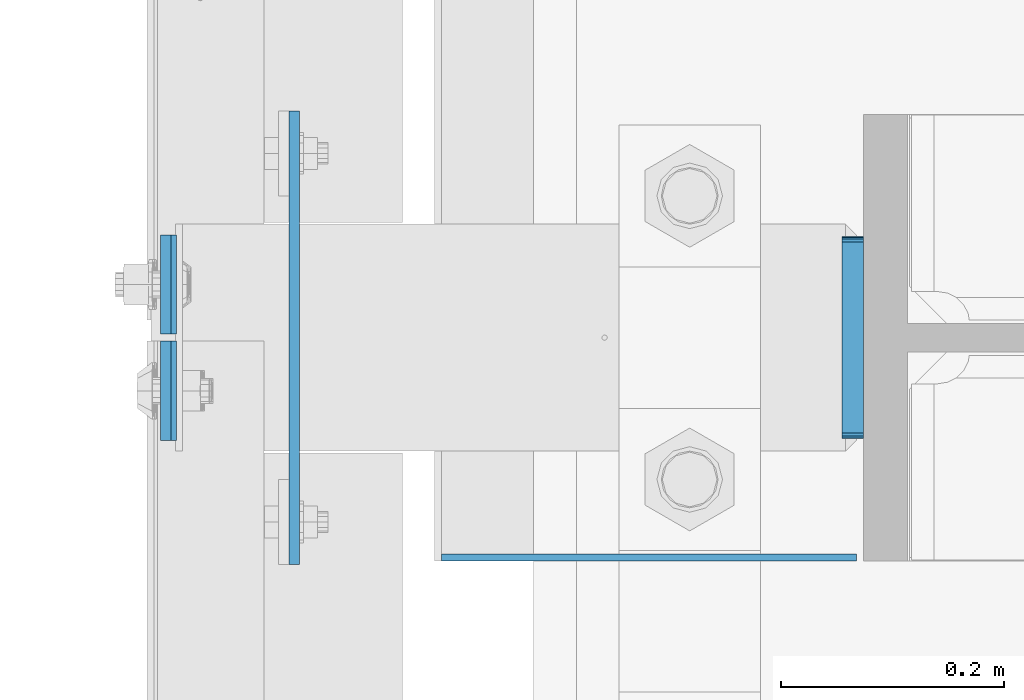
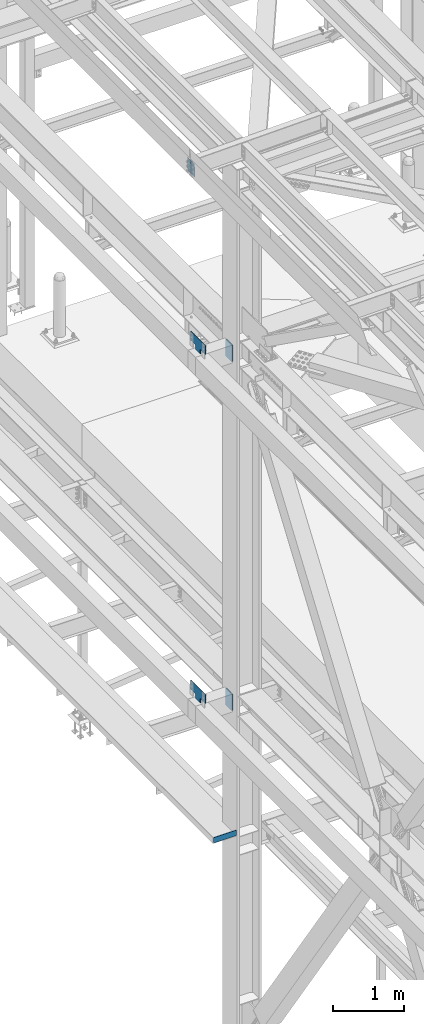
# One storey, part 3360 of 3843: 7 plates, 3 elements without a shape of their own.
"""IFC2X3 building model written with IfcOpenShell, lengths in millimetres."""

from ifc_helpers import new_model, si_unit, frame, origin_with_axes, place, context, subcontext, project, spatial, faceted_brep, material, type_object, element, aggregate, save


model = new_model("IFC2X3")

# Units and contexts
model_context = context("Model", 3, precision=1e-05, world=origin_with_axes())
body_context = subcontext(model_context, "Body", "Model", "MODEL_VIEW")
ifc_project = project(units=[si_unit("LENGTHUNIT", "METRE", prefix="MILLI"), si_unit("AREAUNIT", "SQUARE_METRE"), si_unit("VOLUMEUNIT", "CUBIC_METRE"), si_unit("MASSUNIT", "GRAM", prefix="KILO"), si_unit("TIMEUNIT", "SECOND"), si_unit("PLANEANGLEUNIT", "RADIAN"), si_unit("SOLIDANGLEUNIT", "STERADIAN"), si_unit("THERMODYNAMICTEMPERATUREUNIT", "DEGREE_CELSIUS"), si_unit("LUMINOUSINTENSITYUNIT", "LUMEN")], contexts=[model_context])

# Site, building, storey
site_placement = place(None, origin_with_axes())
site = spatial("IfcSite", under=ifc_project, at=site_placement, CompositionType="ELEMENT")
building_placement = place(site_placement, origin_with_axes())
building = spatial("IfcBuilding", under=site, at=building_placement, Name="Undefined", CompositionType="ELEMENT")
storey_placement = place(building_placement, origin_with_axes())
storey = spatial("IfcBuildingStorey", under=building, at=storey_placement, Name="Undefined", CompositionType="ELEMENT", Elevation=0.0)

# Assembly, plates
assembly_1_placement = place(storey_placement, origin_with_axes())
assembly_1 = element("IfcElementAssembly", 1, at=assembly_1_placement, inside=storey, Name="BEAM", AssemblyPlace="NOTDEFINED", PredefinedType="RIGID_FRAME")
ifc_material = material(Name="STEEL/A572-50")
plate_type_1 = type_object("IfcPlateType", PredefinedType="NOTDEFINED")
plate_1_placement = place(assembly_1_placement, frame((35751.3030535321, 75625.325, 45674.0381290249), z_axis=(0.0, -1.0, 0.0), x_axis=(0.0211520550054438, 0.0, -0.999776270257025)))
plate_1 = element("IfcPlate", 2, at=plate_1_placement, type_object=plate_type_1, material=ifc_material, Name="PLATE", context=body_context, shape_type="Brep", body=[
    faceted_brep([(0.0, -4.76249999999709, 0.0), (0.0, -4.76249999999709, 88.9000015258789), (0.0, 4.76249999999709, 88.9000015258789), (0.0, 4.76249999999709, 0.0), (228.600006102781, -4.7625000004191, 88.9000015257589), (228.600006102781, 4.76249999954598, 88.9000015257443), (228.600006103079, -4.7625000004482, 7.27595761418343e-12), (228.600006103079, 4.76249999954598, -7.27595761418343e-12)], [[[0, 1, 2, 3]], [[1, 4, 5, 2]], [[4, 6, 7, 5]], [[6, 0, 3, 7]], [[5, 7, 3, 2]], [[6, 4, 1, 0]]]),
])
plate_2_placement = place(assembly_1_placement, frame((35751.3030535433, 75631.675, 45674.0381290389), z_axis=(0.0, 1.0, 0.0), x_axis=(0.0211520550054438, 0.0, -0.999776270257025)))
plate_2 = element("IfcPlate", 3, at=plate_2_placement, type_object=plate_type_1, material=ifc_material, Name="PLATE", context=body_context, shape_type="Brep", body=[
    faceted_brep([(0.0, -4.76249999999709, 0.0), (0.0, -4.76249999999709, 88.9000015258789), (0.0, 4.76249999999709, 88.9000015258789), (0.0, 4.76249999999709, 0.0), (228.600006102781, -4.7625000004191, 88.9000015257589), (228.600006102781, 4.76249999954598, 88.9000015257443), (228.600006103079, -4.7625000004482, 7.27595761418343e-12), (228.600006103079, 4.76249999954598, -7.27595761418343e-12)], [[[0, 1, 2, 3]], [[1, 4, 5, 2]], [[4, 6, 7, 5]], [[6, 0, 3, 7]], [[5, 7, 3, 2]], [[6, 4, 1, 0]]]),
])
aggregate(assembly_1, [plate_1, plate_2])

# Assembly, plate
assembly_2_placement = place(storey_placement, origin_with_axes())
assembly_2 = element("IfcElementAssembly", 4, at=assembly_2_placement, inside=storey, Name="BEAM", AssemblyPlace="NOTDEFINED", PredefinedType="RIGID_FRAME")
plate_type_2 = type_object("IfcPlateType", PredefinedType="NOTDEFINED")
plate_3_placement = place(assembly_2_placement, frame((35998.1500244141, 75431.65, 34042.35), z_axis=(0.0, 0.0, 1.0), x_axis=(1.0, 0.0, 0.0)))
plate_3 = element("IfcPlate", 5, at=plate_3_placement, type_object=plate_type_2, material=ifc_material, Name="PLATE", context=body_context, shape_type="Brep", body=[
    faceted_brep([(4.36557456851006e-11, -3.17499999998836, 19.0499992370969), (-2.44140610448085e-05, -3.17500000000291, 95.2499999999927), (-2.44140610448085e-05, 3.17500000000291, 95.2499999999927), (1.45519152283669e-11, 3.17499999998836, 19.0499992370824), (371.474975585938, -3.17500000000291, 95.2499999999927), (371.474975585938, 3.17500000000291, 95.2499999999927), (371.474975585938, -3.17500000000291, 0.0), (371.474975585938, 3.17500000000291, 0.0), (19.0499992370023, -3.17500000005384, 0.0), (19.0499992369587, 3.17499999992287, -1.45519152283669e-11)], [[[0, 1, 2, 3]], [[1, 4, 5, 2]], [[4, 6, 7, 5]], [[6, 8, 9, 7]], [[8, 0, 3, 9]], [[5, 7, 9, 3, 2]], [[8, 6, 4, 1, 0]]]),
])
aggregate(assembly_2, [plate_3])

# Assembly, plates
assembly_3_placement = place(storey_placement, origin_with_axes())
assembly_3 = element("IfcElementAssembly", 6, at=assembly_3_placement, inside=storey, Name="COLUMN", AssemblyPlace="NOTDEFINED", PredefinedType="RIGID_FRAME")
plate_type_3 = type_object("IfcPlateType", PredefinedType="NOTDEFINED")
plate_4_placement = place(assembly_3_placement, frame((35866.3875, 75692.0, 36404.55), z_axis=(0.0, 0.0, 1.0), x_axis=(0.0, -1.0, 0.0)))
plate_4 = element("IfcPlate", 7, at=plate_4_placement, type_object=plate_type_3, material=ifc_material, Name="PLATE", context=body_context, shape_type="Brep", body=[
    faceted_brep([(0.0, -4.76249999999709, 0.0), (-3.49245965480804e-10, -4.76249999999709, 76.1999999999462), (-3.49245965480804e-10, 4.76249999999709, 76.1999999999462), (0.0, 4.76249999999709, 0.0), (-139.699996948242, -4.76249999999709, 76.1999969482422), (-139.699996948242, 4.76249999999709, 76.1999969482422), (-139.699996948242, -4.76249999999709, 228.600006103516), (-139.699996948242, 4.76249999999709, 228.600006103516), (266.700012207031, -4.76249999999709, 228.600006103516), (266.700012207031, 4.76249999999709, 228.600006103516), (266.700012207031, -4.76249999999709, 76.1999969482422), (266.700012207031, 4.76249999999709, 76.1999969482422), (126.999992370605, -4.76249999999709, 76.1999969482422), (126.999992370605, 4.76249999999709, 76.1999969482422), (126.999992370605, -4.76249999999709, 0.0), (126.999992370605, 4.76249999999709, 0.0)], [[[0, 1, 2, 3]], [[1, 4, 5, 2]], [[4, 6, 7, 5]], [[6, 8, 9, 7]], [[8, 10, 11, 9]], [[10, 12, 13, 11]], [[12, 14, 15, 13]], [[14, 0, 3, 15]], [[5, 7, 9, 11, 13, 15, 3, 2]], [[14, 12, 10, 8, 6, 4, 1, 0]]]),
])
plate_5_placement = place(assembly_3_placement, frame((35866.3875, 75692.0, 42367.2), z_axis=(0.0, 0.0, 1.0), x_axis=(0.0, -1.0, 0.0)))
plate_5 = element("IfcPlate", 8, at=plate_5_placement, type_object=plate_type_3, material=ifc_material, Name="PLATE", context=body_context, shape_type="Brep", body=[
    faceted_brep([(0.0, -4.76249999999709, 0.0), (-3.49245965480804e-10, -4.76249999999709, 76.1999999999462), (-3.49245965480804e-10, 4.76249999999709, 76.1999999999462), (0.0, 4.76249999999709, 0.0), (-139.699996948242, -4.76249999999709, 76.1999969482422), (-139.699996948242, 4.76249999999709, 76.1999969482422), (-139.699996948242, -4.76249999999709, 228.600006103516), (-139.699996948242, 4.76249999999709, 228.600006103516), (266.700012207031, -4.76249999999709, 228.600006103516), (266.700012207031, 4.76249999999709, 228.600006103516), (266.700012207031, -4.76249999999709, 76.1999969482422), (266.700012207031, 4.76249999999709, 76.1999969482422), (126.999992370605, -4.76249999999709, 76.1999969482422), (126.999992370605, 4.76249999999709, 76.1999969482422), (126.999992370605, -4.76249999999709, 0.0), (126.999992370605, 4.76249999999709, 0.0)], [[[0, 1, 2, 3]], [[1, 4, 5, 2]], [[4, 6, 7, 5]], [[6, 8, 9, 7]], [[8, 10, 11, 9]], [[10, 12, 13, 11]], [[12, 14, 15, 13]], [[14, 0, 3, 15]], [[5, 7, 9, 11, 13, 15, 3, 2]], [[14, 12, 10, 8, 6, 4, 1, 0]]]),
])
plate_type_4 = type_object("IfcPlateType", PredefinedType="NOTDEFINED")
plate_6_placement = place(assembly_3_placement, frame((36366.45, 75538.0125, 42356.4551879883), z_axis=(0.0, 1.0, 0.0), x_axis=(0.0, 0.0, -1.0)))
plate_6 = element("IfcPlate", 9, at=plate_6_placement, type_object=plate_type_4, material=ifc_material, Name="PLATE", context=body_context, shape_type="Brep", body=[
    faceted_brep([(-8.22591685395256e-13, -9.52499999999854, 7.9375), (0.0, -9.52499999999418, 173.037499999991), (0.0, 9.52499999999418, 173.037499999991), (0.0, 9.52499999999418, 7.9375), (0.604206210693519, -9.52499999999418, 176.075049744395), (0.604206210693519, 9.52499999999418, 176.075049744395), (2.32483992433117, -9.52499999999418, 178.65016007566), (2.32483992433117, 9.52499999999418, 178.65016007566), (4.89995025560347, -9.52499999999418, 180.370793789305), (4.89995025560347, 9.52499999999418, 180.370793789305), (7.9375, -9.52499999999418, 180.974999999991), (7.9375, 9.52499999999418, 180.974999999991), (274.637499999997, -9.52499999999418, 180.974999999991), (274.637499999997, 9.52499999999418, 180.974999999991), (277.675049744394, -9.52499999999418, 180.370793789305), (277.675049744394, 9.52499999999418, 180.370793789305), (280.250160075666, -9.52499999999418, 178.65016007566), (280.250160075666, 9.52499999999418, 178.65016007566), (281.970793789304, -9.52499999999418, 176.075049744395), (281.970793789304, 9.52499999999418, 176.075049744395), (282.574999999997, -9.52499999999418, 173.037499999991), (282.574999999997, 9.52499999999418, 173.037499999991), (282.574999999997, -9.52499999999418, 7.9375), (282.574999999997, 9.52499999999418, 7.9375), (281.970793789304, -9.52499999999418, 4.8999502555962), (281.970793789304, 9.52499999999418, 4.8999502555962), (280.250160075666, -9.52499999999418, 2.32483992433117), (280.250160075666, 9.52499999999418, 2.32483992433117), (277.675049744394, -9.52499999999418, 0.604206210686243), (277.675049744394, 9.52499999999418, 0.604206210686243), (274.637499999997, -9.52499999999418, 0.0), (274.637499999997, 9.52499999999418, 0.0), (7.9375, -9.52499999999854, 0.0), (7.9375, 9.52499999999418, 0.0), (4.8999502555962, -9.52499999999418, 0.604206210693519), (4.8999502555962, 9.52499999999418, 0.604206210693519), (2.32483992433117, -9.52499999999418, 2.32483992433117), (2.32483992433117, 9.52499999999418, 2.32483992433117), (0.604206210686243, -9.52499999999418, 4.89995025560347), (0.604206210686243, 9.52499999999418, 4.89995025560347)], [[[0, 1, 2, 3]], [[1, 4, 5, 2]], [[4, 6, 7, 5]], [[6, 8, 9, 7]], [[8, 10, 11, 9]], [[10, 12, 13, 11]], [[12, 14, 15, 13]], [[14, 16, 17, 15]], [[16, 18, 19, 17]], [[18, 20, 21, 19]], [[20, 22, 23, 21]], [[22, 24, 25, 23]], [[24, 26, 27, 25]], [[26, 28, 29, 27]], [[28, 30, 31, 29]], [[30, 32, 33, 31]], [[32, 34, 35, 33]], [[34, 36, 37, 35]], [[36, 38, 39, 37]], [[38, 0, 3, 39]], [[5, 7, 9, 11, 13, 15, 17, 19, 21, 23, 25, 27, 29, 31, 33, 35, 37, 39, 3, 2]], [[38, 36, 34, 32, 30, 28, 26, 24, 22, 20, 18, 16, 14, 12, 10, 8, 6, 4, 1, 0]]]),
])
plate_7_placement = place(assembly_3_placement, frame((36366.45, 75538.0125, 36393.4375), z_axis=(0.0, 1.0, 0.0), x_axis=(0.0, 0.0, -1.0)))
plate_7 = element("IfcPlate", 10, at=plate_7_placement, type_object=plate_type_4, material=ifc_material, Name="PLATE", context=body_context, shape_type="Brep", body=[
    faceted_brep([(-8.22591685395256e-13, -9.52499999999854, 7.9375), (0.0, -9.52499999999418, 173.037499999991), (0.0, 9.52499999999418, 173.037499999991), (0.0, 9.52499999999418, 7.9375), (0.604206210693519, -9.52499999999418, 176.075049744395), (0.604206210693519, 9.52499999999418, 176.075049744395), (2.32483992433117, -9.52499999999418, 178.65016007566), (2.32483992433117, 9.52499999999418, 178.65016007566), (4.89995025560347, -9.52499999999418, 180.370793789305), (4.89995025560347, 9.52499999999418, 180.370793789305), (7.9375, -9.52499999999418, 180.974999999991), (7.9375, 9.52499999999418, 180.974999999991), (274.637499999997, -9.52499999999418, 180.974999999991), (274.637499999997, 9.52499999999418, 180.974999999991), (277.675049744394, -9.52499999999418, 180.370793789305), (277.675049744394, 9.52499999999418, 180.370793789305), (280.250160075666, -9.52499999999418, 178.65016007566), (280.250160075666, 9.52499999999418, 178.65016007566), (281.970793789304, -9.52499999999418, 176.075049744395), (281.970793789304, 9.52499999999418, 176.075049744395), (282.574999999997, -9.52499999999418, 173.037499999991), (282.574999999997, 9.52499999999418, 173.037499999991), (282.574999999997, -9.52499999999418, 7.9375), (282.574999999997, 9.52499999999418, 7.9375), (281.970793789304, -9.52499999999418, 4.8999502555962), (281.970793789304, 9.52499999999418, 4.8999502555962), (280.250160075666, -9.52499999999418, 2.32483992433117), (280.250160075666, 9.52499999999418, 2.32483992433117), (277.675049744394, -9.52499999999418, 0.604206210686243), (277.675049744394, 9.52499999999418, 0.604206210686243), (274.637499999997, -9.52499999999418, 0.0), (274.637499999997, 9.52499999999418, 0.0), (7.9375, -9.52499999999854, 0.0), (7.9375, 9.52499999999418, 0.0), (4.8999502555962, -9.52499999999418, 0.604206210693519), (4.8999502555962, 9.52499999999418, 0.604206210693519), (2.32483992433117, -9.52499999999418, 2.32483992433117), (2.32483992433117, 9.52499999999418, 2.32483992433117), (0.604206210686243, -9.52499999999418, 4.89995025560347), (0.604206210686243, 9.52499999999418, 4.89995025560347)], [[[0, 1, 2, 3]], [[1, 4, 5, 2]], [[4, 6, 7, 5]], [[6, 8, 9, 7]], [[8, 10, 11, 9]], [[10, 12, 13, 11]], [[12, 14, 15, 13]], [[14, 16, 17, 15]], [[16, 18, 19, 17]], [[18, 20, 21, 19]], [[20, 22, 23, 21]], [[22, 24, 25, 23]], [[24, 26, 27, 25]], [[26, 28, 29, 27]], [[28, 30, 31, 29]], [[30, 32, 33, 31]], [[32, 34, 35, 33]], [[34, 36, 37, 35]], [[36, 38, 39, 37]], [[38, 0, 3, 39]], [[5, 7, 9, 11, 13, 15, 17, 19, 21, 23, 25, 27, 29, 31, 33, 35, 37, 39, 3, 2]], [[38, 36, 34, 32, 30, 28, 26, 24, 22, 20, 18, 16, 14, 12, 10, 8, 6, 4, 1, 0]]]),
])
aggregate(assembly_3, [plate_6, plate_7, plate_4, plate_5])

save(model, "model.ifc")
